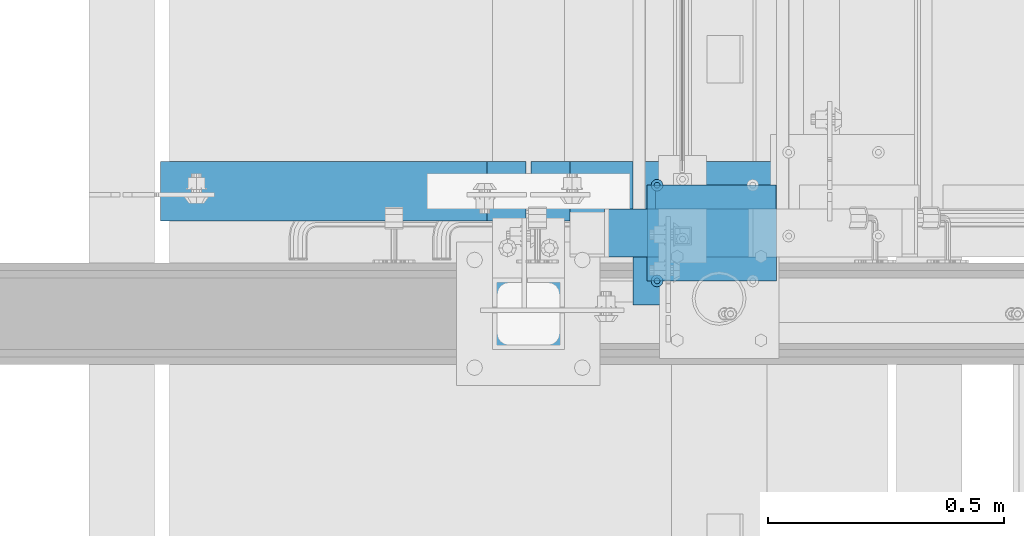
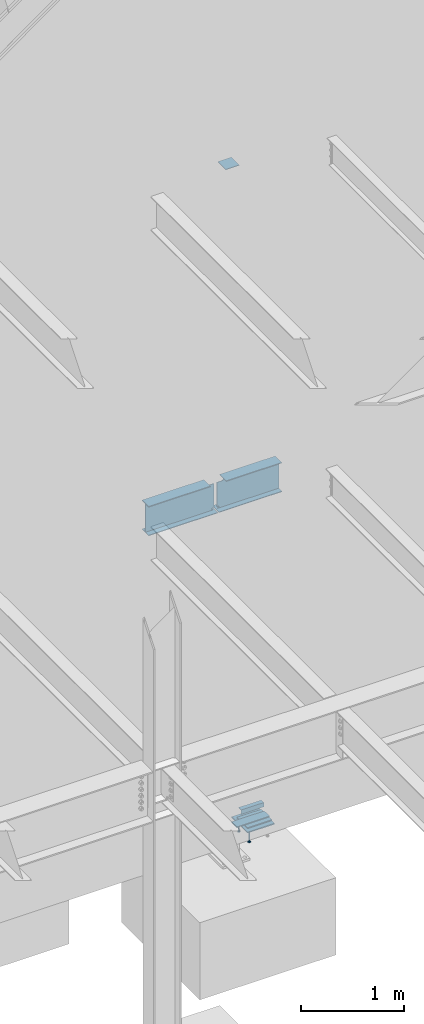
# One storey, part 903 of 1179: 11 beams, 8 elements without a shape of their own.
"""IFC2X3 building model written with IfcOpenShell, lengths in millimetres."""

from ifc_helpers import new_model, si_unit, frame, origin_with_axes, place, context, subcontext, project, spatial, faceted_brep, material, type_object, element, aggregate, save


model = new_model("IFC2X3")

# Units and contexts
model_context = context("Model", 3, precision=1e-05, world=origin_with_axes())
body_context = subcontext(model_context, "Body", "Model", "MODEL_VIEW")
ifc_project = project(units=[si_unit("LENGTHUNIT", "METRE", prefix="MILLI"), si_unit("AREAUNIT", "SQUARE_METRE"), si_unit("VOLUMEUNIT", "CUBIC_METRE"), si_unit("MASSUNIT", "GRAM", prefix="KILO"), si_unit("TIMEUNIT", "SECOND"), si_unit("PLANEANGLEUNIT", "RADIAN"), si_unit("SOLIDANGLEUNIT", "STERADIAN"), si_unit("THERMODYNAMICTEMPERATUREUNIT", "DEGREE_CELSIUS"), si_unit("LUMINOUSINTENSITYUNIT", "LUMEN")], contexts=[model_context])

# Site, building, storey
site_placement = place(None, origin_with_axes())
site = spatial("IfcSite", under=ifc_project, at=site_placement, CompositionType="ELEMENT")
building_placement = place(site_placement, origin_with_axes())
building = spatial("IfcBuilding", under=site, at=building_placement, Name="Undefined", CompositionType="ELEMENT")
storey_placement = place(building_placement, origin_with_axes())
storey = spatial("IfcBuildingStorey", under=building, at=storey_placement, Name="Undefined", CompositionType="ELEMENT", Elevation=0.0)

# Assembly, beam
assembly_1_placement = place(storey_placement, origin_with_axes())
assembly_1 = element("IfcElementAssembly", 1, at=assembly_1_placement, inside=storey, Name="STAIR", AssemblyPlace="NOTDEFINED", PredefinedType="RIGID_FRAME")
ifc_material_1 = material(Name="STEEL/A36")
beam_type_1 = type_object("IfcBeamType", Name="L2X2X3/16", PredefinedType="NOTDEFINED")
beam_1_placement = place(assembly_1_placement, frame((19802.8678269992, 38233.3500000384, 97.6973832800095), z_axis=(0.0, 1.0, 0.0), x_axis=(-1.0, 0.0, 0.0)))
beam_1 = element("IfcBeam", 2, at=beam_1_placement, type_object=beam_type_1, material=ifc_material_1, Name="ANGLE", ObjectType="L2X2X3/16", context=body_context, shape_type="Brep", body=[
    faceted_brep([(0.0, 25.3999999999996, -25.4000000000015), (0.0, 25.3999999999996, 25.4000000000015), (254.0, 25.3999999999996, 25.4000000000001), (254.0, 25.3999999999996, -25.4000000000001), (0.0, 20.6374999999998, 25.4000000000015), (254.0, 20.6374999999998, 25.4000000000001), (0.0, 20.6374999999998, -20.6374999999971), (254.0, 20.6374999999998, -20.6374999999998), (0.0, -25.3999999999996, -20.6374999999971), (254.0, -25.3999999999996, -20.6374999999998), (0.0, -25.3999999999996, -25.4000000000015), (254.0, -25.3999999999996, -25.4000000000001)], [[[0, 1, 2, 3]], [[1, 4, 5, 2]], [[4, 6, 7, 5]], [[6, 8, 9, 7]], [[8, 10, 11, 9]], [[10, 0, 3, 11]], [[5, 7, 9, 11, 3, 2]], [[10, 8, 6, 4, 1, 0]]]),
])

# Assembly, beams
assembly_2_placement = place(storey_placement, origin_with_axes())
assembly_2 = element("IfcElementAssembly", 3, at=assembly_2_placement, inside=storey, Name="EMBED", AssemblyPlace="NOTDEFINED", PredefinedType="RIGID_FRAME")
ifc_material_2 = material(Name="STEEL/A108")
beam_type_2 = type_object("IfcBeamType", Name="STUD_1/2-DIA", PredefinedType="NOTDEFINED")
beam_2_placement = place(assembly_2_placement, frame((19551.6500003795, 38055.5499999969, -12.6999999999994), z_axis=(0.0, -1.0, 0.0), x_axis=(0.0, 0.0, -1.0)))
beam_2 = element("IfcBeam", 4, at=beam_2_placement, type_object=beam_type_2, material=ifc_material_2, Name="SHEAR STUD", ObjectType="STUD_1/2-DIA", context=body_context, shape_type="Brep", body=[
    faceted_brep([(0.0, -3.1800000667572, 5.5), (0.0, -5.5, 3.1800000667572), (141.732, -5.5, 3.1800000667572), (141.732, -3.1800000667572, 5.5), (0.0, -6.34999999999854, 0.0), (141.732, -6.34999990463257, 0.0), (0.0, -5.5, -3.1800000667572), (141.732, -5.5, -3.1800000667572), (0.0, -3.1800000667572, -5.5), (141.732, -3.1800000667572, -5.5), (0.0, 0.0, -6.34999999999991), (141.732, 0.0, -6.34999990463257), (0.0, 3.1800000667572, -5.5), (141.732, 3.1800000667572, -5.5), (0.0, 5.5, -3.1800000667572), (141.732, 5.5, -3.1800000667572), (0.0, 6.34999999999854, 0.0), (141.732, 6.34999990463257, 0.0), (0.0, 5.5, 3.1800000667572), (141.732, 5.5, 3.1800000667572), (0.0, 3.1800000667572, 5.5), (141.732, 3.1800000667572, 5.5), (0.0, 0.0, 6.34999999999991), (141.732, 0.0, 6.34999990463257), (144.78, -10.9899997711182, 6.34999990463257), (144.78, -6.34000015258789, 10.9899997711182), (144.78, -12.6999998092651, 0.0), (144.78, -10.9899997711182, -6.34999990463257), (144.78, -6.34000015258789, -10.9899997711182), (144.78, 0.0, -12.6899995803833), (144.78, 6.34000015258789, -10.9899997711182), (144.78, 10.9899997711182, -6.34999990463257), (144.78, 12.6999998092651, 0.0), (144.78, 10.9899997711182, 6.34999990463257), (144.78, 6.34000015258789, 10.9899997711182), (144.78, 0.0, 12.6899995803833), (152.4, -10.9899997711182, 6.34999990463257), (152.4, -6.34000015258789, 10.9899997711182), (152.4, -12.6999998092651, 0.0), (152.4, -10.9899997711182, -6.34999990463257), (152.4, -6.34000015258789, -10.9899997711182), (152.4, 0.0, -12.6899995803833), (152.4, 6.34000015258789, -10.9899997711182), (152.4, 10.9899997711182, -6.34999990463257), (152.4, 12.6999998092651, 0.0), (152.4, 10.9899997711182, 6.34999990463257), (152.4, 6.34000015258789, 10.9899997711182), (152.4, 0.0, 12.6899995803833)], [[[0, 1, 2, 3]], [[1, 4, 5, 2]], [[4, 6, 7, 5]], [[6, 8, 9, 7]], [[8, 10, 11, 9]], [[10, 12, 13, 11]], [[12, 14, 15, 13]], [[14, 16, 17, 15]], [[16, 18, 19, 17]], [[18, 20, 21, 19]], [[20, 22, 23, 21]], [[22, 0, 3, 23]], [[22, 20, 18, 16, 14, 12, 10, 8, 6, 4, 1, 0]], [[3, 2, 24, 25]], [[2, 5, 26, 24]], [[5, 7, 27, 26]], [[7, 9, 28, 27]], [[9, 11, 29, 28]], [[11, 13, 30, 29]], [[13, 15, 31, 30]], [[15, 17, 32, 31]], [[17, 19, 33, 32]], [[19, 21, 34, 33]], [[21, 23, 35, 34]], [[23, 3, 25, 35]], [[25, 24, 36, 37]], [[24, 26, 38, 36]], [[26, 27, 39, 38]], [[27, 28, 40, 39]], [[28, 29, 41, 40]], [[29, 30, 42, 41]], [[30, 31, 43, 42]], [[31, 32, 44, 43]], [[32, 33, 45, 44]], [[33, 34, 46, 45]], [[34, 35, 47, 46]], [[35, 25, 37, 47]], [[38, 39, 40, 41, 42, 43, 44, 45, 46, 47, 37, 36]]]),
])
beam_3_placement = place(assembly_2_placement, frame((19551.6500003795, 38258.7499999968, -12.6999999999994), z_axis=(0.0, -1.0, 0.0), x_axis=(0.0, 0.0, -1.0)))
beam_3 = element("IfcBeam", 5, at=beam_3_placement, type_object=beam_type_2, material=ifc_material_2, Name="SHEAR STUD", ObjectType="STUD_1/2-DIA", context=body_context, shape_type="Brep", body=[
    faceted_brep([(0.0, -3.1800000667572, 5.5), (0.0, -5.5, 3.1800000667572), (141.732, -5.5, 3.1800000667572), (141.732, -3.1800000667572, 5.5), (0.0, -6.34999999999854, 0.0), (141.732, -6.34999990463257, 0.0), (0.0, -5.5, -3.1800000667572), (141.732, -5.5, -3.1800000667572), (0.0, -3.1800000667572, -5.5), (141.732, -3.1800000667572, -5.5), (0.0, 0.0, -6.34999999999991), (141.732, 0.0, -6.34999990463257), (0.0, 3.1800000667572, -5.5), (141.732, 3.1800000667572, -5.5), (0.0, 5.5, -3.1800000667572), (141.732, 5.5, -3.1800000667572), (0.0, 6.34999999999854, 0.0), (141.732, 6.34999990463257, 0.0), (0.0, 5.5, 3.1800000667572), (141.732, 5.5, 3.1800000667572), (0.0, 3.1800000667572, 5.5), (141.732, 3.1800000667572, 5.5), (0.0, 0.0, 6.34999999999991), (141.732, 0.0, 6.34999990463257), (144.78, -10.9899997711182, 6.34999990463257), (144.78, -6.34000015258789, 10.9899997711182), (144.78, -12.6999998092651, 0.0), (144.78, -10.9899997711182, -6.34999990463257), (144.78, -6.34000015258789, -10.9899997711182), (144.78, 0.0, -12.6899995803833), (144.78, 6.34000015258789, -10.9899997711182), (144.78, 10.9899997711182, -6.34999990463257), (144.78, 12.6999998092651, 0.0), (144.78, 10.9899997711182, 6.34999990463257), (144.78, 6.34000015258789, 10.9899997711182), (144.78, 0.0, 12.6899995803833), (152.4, -10.9899997711182, 6.34999990463257), (152.4, -6.34000015258789, 10.9899997711182), (152.4, -12.6999998092651, 0.0), (152.4, -10.9899997711182, -6.34999990463257), (152.4, -6.34000015258789, -10.9899997711182), (152.4, 0.0, -12.6899995803833), (152.4, 6.34000015258789, -10.9899997711182), (152.4, 10.9899997711182, -6.34999990463257), (152.4, 12.6999998092651, 0.0), (152.4, 10.9899997711182, 6.34999990463257), (152.4, 6.34000015258789, 10.9899997711182), (152.4, 0.0, 12.6899995803833)], [[[0, 1, 2, 3]], [[1, 4, 5, 2]], [[4, 6, 7, 5]], [[6, 8, 9, 7]], [[8, 10, 11, 9]], [[10, 12, 13, 11]], [[12, 14, 15, 13]], [[14, 16, 17, 15]], [[16, 18, 19, 17]], [[18, 20, 21, 19]], [[20, 22, 23, 21]], [[22, 0, 3, 23]], [[22, 20, 18, 16, 14, 12, 10, 8, 6, 4, 1, 0]], [[3, 2, 24, 25]], [[2, 5, 26, 24]], [[5, 7, 27, 26]], [[7, 9, 28, 27]], [[9, 11, 29, 28]], [[11, 13, 30, 29]], [[13, 15, 31, 30]], [[15, 17, 32, 31]], [[17, 19, 33, 32]], [[19, 21, 34, 33]], [[21, 23, 35, 34]], [[23, 3, 25, 35]], [[25, 24, 36, 37]], [[24, 26, 38, 36]], [[26, 27, 39, 38]], [[27, 28, 40, 39]], [[28, 29, 41, 40]], [[29, 30, 42, 41]], [[30, 31, 43, 42]], [[31, 32, 44, 43]], [[32, 33, 45, 44]], [[33, 34, 46, 45]], [[34, 35, 47, 46]], [[35, 25, 37, 47]], [[38, 39, 40, 41, 42, 43, 44, 45, 46, 47, 37, 36]]]),
])

# Beam
beam_type_3 = type_object("IfcBeamType", PredefinedType="NOTDEFINED")
beam_4_placement = place(assembly_1_placement, frame((19808.6125266123, 38157.1500000141, 17.5288666593273), z_axis=(0.0, -1.0, 0.0), x_axis=(-1.0, 0.0, 0.0)))
beam_4 = element("IfcBeam", 6, at=beam_4_placement, type_object=beam_type_3, material=ifc_material_1, Name="PLATE", context=body_context, shape_type="Brep", body=[
    faceted_brep([(0.0, 4.76249999999982, -50.7999999999993), (0.0, 4.76249999999982, 50.7999999999993), (368.087195261149, 4.76249999999948, 50.8000000000029), (368.087195261149, 4.76249999999948, -50.8000000000029), (0.0, -4.76249999999982, 50.7999999999993), (368.087195261145, -4.76250000000052, 50.8000000000029), (0.0, -4.76249999999982, -50.7999999999993), (368.087195261145, -4.76250000000052, -50.8000000000029)], [[[0, 1, 2, 3]], [[1, 4, 5, 2]], [[4, 6, 7, 5]], [[6, 0, 3, 7]], [[5, 7, 3, 2]], [[6, 4, 1, 0]]]),
])

aggregate(assembly_1, [beam_4, beam_1])

# Assembly, beam
assembly_3_placement = place(storey_placement, origin_with_axes())
assembly_3 = element("IfcElementAssembly", 7, at=assembly_3_placement, inside=storey, Name="LAYER", AssemblyPlace="NOTDEFINED", PredefinedType="RIGID_FRAME")
beam_type_4 = type_object("IfcBeamType", PredefinedType="NOTDEFINED")
beam_5_placement = place(assembly_3_placement, frame((19805.6497468088, 38157.1499999975, 6.34981667033696), z_axis=(0.0, -1.0, 0.0), x_axis=(-1.0, 0.0, 0.0)))
beam_5 = element("IfcBeam", 8, at=beam_5_placement, type_object=beam_type_4, material=ifc_material_1, Name="LAYER", context=body_context, shape_type="Brep", body=[
    faceted_brep([(1.77351466845721e-11, 3.17500000001064, -101.600000000029), (0.0, 3.17500000000018, 101.599999999999), (275.436220746942, 3.17500000000001, 101.599999999999), (275.436220746942, 3.17500000000001, -101.599999999999), (0.0, -3.17500000000018, 101.599999999999), (275.436220746949, -3.17499999999999, 101.599999999999), (1.8644641386345e-11, -3.17499999998927, -101.600000000031), (275.436220746949, -3.17499999999999, -101.599999999999)], [[[0, 1, 2, 3]], [[1, 4, 5, 2]], [[4, 6, 7, 5]], [[6, 0, 3, 7]], [[5, 7, 3, 2]], [[6, 4, 1, 0]]]),
])
aggregate(assembly_3, [beam_5])

assembly_4_placement = place(storey_placement, origin_with_axes())
assembly_4 = element("IfcElementAssembly", 9, at=assembly_4_placement, inside=storey, Name="BEAM", AssemblyPlace="NOTDEFINED", PredefinedType="RIGID_FRAME")
ifc_material_3 = material(Name="STEEL/A992")
beam_type_5 = type_object("IfcBeamType", Name="W14X22", PredefinedType="NOTDEFINED")
beam_6_placement = place(assembly_4_placement, frame((18415.0, 38246.0500000005, 3927.475), z_axis=(0.0, 0.0, 1.0), x_axis=(1.0, 0.0, 0.0)))
beam_6 = element("IfcBeam", 10, at=beam_6_placement, type_object=beam_type_5, material=ifc_material_3, Name="BEAM", ObjectType="W14X22", context=body_context, shape_type="Brep", body=[
    faceted_brep([(846.931249999998, -3.17500000000291, -166.3875), (846.931249999998, 3.17500000000291, -166.3875), (838.993749999998, 3.17500000000291, -166.3875), (838.993749999998, -3.17500000000291, -166.3875), (825.823690306723, 3.17500000000291, -160.932282657781), (825.823690306723, -3.17500000000291, -160.932282657781), (821.549002259999, 3.17500000000291, -157.42413636819), (821.549002259999, -3.17500000000291, -157.42413636819), (819.94375038147, 3.17500000000291, -152.132330110611), (819.94375038147, -3.17500000000291, -152.132330110611), (821.549002259999, 3.17500000000291, -146.840523853033), (821.549002259999, -3.17500000000291, -146.840523853033), (825.823690452704, 3.17500000000291, -143.332377915873), (825.823690452704, -3.17500000000291, -143.332377915873), (846.931249999998, -3.17500000000291, -142.907330326454), (846.931249999998, 3.17500000000291, -142.907330326454), (82.5499999999993, 3.17500000000291, 166.6875), (82.5499999999993, 63.5, 166.6875), (775.493749999998, 63.5, 166.6875), (775.493749999998, 3.17500000000291, 166.6875), (82.5499999999993, -63.5, -174.625), (82.5499999999993, 63.5, -174.625), (858.043749999997, 63.5, -174.625), (858.043749999997, -63.5, -174.625), (846.931249999998, -63.5, -166.6875), (82.5499999999993, -63.5, -166.6875), (858.043749999997, -63.5, -166.6875), (846.931249999998, -3.17500000000291, -166.6875), (82.5499999999993, -3.17500000000291, -166.6875), (858.043749999997, -3.17500000000291, -166.6875), (846.931249999998, 63.5, -166.6875), (82.5499999999993, 63.5, -166.6875), (82.5499999999993, 3.17500000000291, -166.6875), (846.931249999998, 3.17500000000291, -166.6875), (858.043749999997, 3.17500000000291, -166.6875), (858.043749999997, 63.5, -166.6875), (82.5499999999993, -3.17500000000291, 166.6875), (82.5499999999993, -63.5, 166.6875), (82.5499999999993, -63.5, 174.625), (82.5499999999993, 63.5, 174.625), (775.493749999998, -3.17500000000291, 166.6875), (775.493749999998, -63.5, 166.6875), (775.493749999998, -63.5, 174.625), (775.493749999998, 63.5, 174.625), (775.493749999998, -3.17500000000291, 155.574999809468), (775.493749999998, 3.17500000000291, 155.574999809468), (776.460479922585, -3.17500000000291, 150.714920291423), (776.460479922585, 3.17500000000291, 150.714920291423), (779.213493823063, -3.17500000000291, 146.594743823269), (779.213493823063, 3.17500000000291, 146.594743823269), (783.333670291217, -3.17500000000291, 143.841729922791), (783.333670291217, 3.17500000000291, 143.841729922791), (788.193749809263, -3.17500000000291, 142.875000000203), (788.193749809263, 3.17500000000291, 142.875000000203), (846.931249999998, -3.17500000000291, 142.875000000203), (846.931249999998, 3.17500000000291, 142.875000000203)], [[[0, 1, 2, 3]], [[3, 2, 4, 5]], [[5, 4, 6, 7]], [[7, 6, 8, 9]], [[9, 8, 10, 11]], [[11, 10, 12, 13]], [[14, 13, 12, 15]], [[16, 17, 18, 19]], [[20, 21, 22, 23]], [[24, 25, 20, 23, 26]], [[27, 28, 25, 24, 26, 29]], [[30, 31, 32, 33, 34, 35]], [[29, 34, 33, 27]], [[26, 23, 22, 35, 34, 29]], [[21, 31, 30, 35, 22]], [[20, 25, 28, 36, 37, 38, 39, 17, 16, 32, 31, 21]], [[37, 36, 40, 41]], [[38, 37, 41, 42]], [[39, 38, 42, 43]], [[17, 39, 43, 18]], [[42, 41, 40, 44, 45, 19, 18, 43]], [[46, 47, 45, 44]], [[48, 49, 47, 46]], [[50, 51, 49, 48]], [[52, 53, 51, 50]], [[53, 52, 54, 55]], [[55, 54, 14, 15]], [[10, 8, 6, 4, 2, 1, 33, 32, 16, 19, 45, 47, 49, 51, 53, 55, 15, 12]], [[27, 33, 1, 0]], [[54, 52, 50, 48, 46, 44, 40, 36, 28, 27, 0, 3, 5, 7, 9, 11, 13, 14]]]),
])
aggregate(assembly_4, [beam_6])

assembly_5_placement = place(storey_placement, origin_with_axes())
assembly_5 = element("IfcElementAssembly", 11, at=assembly_5_placement, inside=storey, Name="BEAM", AssemblyPlace="NOTDEFINED", PredefinedType="RIGID_FRAME")
beam_7_placement = place(assembly_5_placement, frame((19278.6, 38246.0500000005, 3927.475), z_axis=(0.0, 0.0, 1.0), x_axis=(1.0, 0.0, 0.0)))
beam_7 = element("IfcBeam", 12, at=beam_7_placement, type_object=beam_type_5, material=ifc_material_3, Name="BEAM", ObjectType="W14X22", context=body_context, shape_type="Brep", body=[
    faceted_brep([(16.6687500000044, -3.17500000000291, -142.907330326454), (16.6687500000044, 3.17500000000291, -142.907330326454), (37.7763095472983, 3.17500000000291, -143.332377915873), (37.7763095472983, -3.17500000000291, -143.332377915873), (42.0509977400034, 3.17500000000291, -146.840523853033), (42.0509977400034, -3.17500000000291, -146.840523853033), (24.6062500000044, -3.17500000000291, -166.3875), (24.6062500000044, 3.17500000000291, -166.3875), (16.6687500000044, 3.17500000000291, -166.3875), (16.6687500000044, -3.17500000000291, -166.3875), (37.7763096932795, -3.17500000000291, -160.932282657781), (37.7763096932795, 3.17500000000291, -160.932282657781), (42.0509977400034, -3.17500000000291, -157.42413636819), (42.0509977400034, 3.17500000000291, -157.42413636819), (43.6562496185325, -3.17500000000291, -152.132330110611), (43.6562496185325, 3.17500000000291, -152.132330110611), (711.199999999997, -63.5, 166.6875), (711.199999999997, -63.5, 174.625), (88.1062500000044, -63.5, 174.625), (88.1062500000044, -63.5, 166.6875), (711.199999999997, 63.5, 174.625), (88.1062500000044, 63.5, 174.625), (711.199999999997, 63.5, 166.6875), (88.1062500000044, 63.5, 166.6875), (711.199999999997, 3.17500000000291, 166.6875), (88.1062500000044, 3.17500000000291, 166.6875), (75.4062501907392, -3.17500000000291, 142.875000000076), (75.4062501907392, 3.17500000000291, 142.875000000076), (16.6687500000007, 3.17500000000291, 142.875), (16.6687500000007, -3.17500000000291, 142.875), (80.2663297087856, -3.17500000000291, 143.841729922664), (80.2663297087856, 3.17500000000291, 143.841729922664), (84.3865061769393, -3.17500000000291, 146.594743823142), (84.3865061769393, 3.17500000000291, 146.594743823142), (87.1395200774168, -3.17500000000291, 150.714920291296), (87.1395200774168, 3.17500000000291, 150.714920291296), (88.1062500000044, -3.17500000000291, 155.574999809341), (88.1062500000044, 3.17500000000291, 155.574999809341), (88.1062500000044, -3.17500000000291, 166.6875), (711.199999999997, -3.17500000000291, 166.6875), (16.6687500000044, 3.17500000000291, -166.6875), (711.199999999997, 3.17500000000291, -166.6875), (711.199999999997, 63.5, -166.6875), (16.6687500000044, 63.5, -166.6875), (5.55625000000509, 63.5, -166.6875), (5.55625000000509, 3.17500000000291, -166.6875), (711.199999999997, -63.5, -174.625), (711.199999999997, -63.5, -166.6875), (16.6687500000044, -63.5, -166.6875), (5.55625000000509, -63.5, -166.6875), (5.55625000000509, -63.5, -174.625), (711.199999999997, 63.5, -174.625), (5.55625000000509, 63.5, -174.625), (711.199999999997, -3.17500000000291, -166.6875), (16.6687500000044, -3.17500000000291, -166.6875), (5.55625000000509, -3.17500000000291, -166.6875)], [[[0, 1, 2, 3]], [[3, 2, 4, 5]], [[6, 7, 8, 9]], [[10, 11, 7, 6]], [[12, 13, 11, 10]], [[14, 15, 13, 12]], [[5, 4, 15, 14]], [[16, 17, 18, 19]], [[17, 20, 21, 18]], [[20, 22, 23, 21]], [[22, 24, 25, 23]], [[26, 27, 28, 29]], [[30, 31, 27, 26]], [[32, 33, 31, 30]], [[34, 35, 33, 32]], [[36, 37, 35, 34]], [[18, 21, 23, 25, 37, 36, 38, 19]], [[39, 16, 19, 38]], [[40, 41, 42, 43, 44, 45]], [[46, 47, 48, 49, 50]], [[51, 46, 50, 52]], [[43, 42, 51, 52, 44]], [[41, 24, 22, 20, 17, 16, 39, 53, 47, 46, 51, 42]], [[48, 47, 53, 54, 55, 49]], [[44, 52, 50, 49, 55, 45]], [[54, 40, 45, 55]], [[40, 54, 9, 8]], [[2, 1, 28, 27, 31, 33, 35, 37, 25, 24, 41, 40, 8, 7, 11, 13, 15, 4]], [[29, 28, 1, 0]], [[10, 6, 9, 54, 53, 39, 38, 36, 34, 32, 30, 26, 29, 0, 3, 5, 14, 12]]]),
])
aggregate(assembly_5, [beam_7])

assembly_6_placement = place(storey_placement, origin_with_axes())
assembly_6 = element("IfcElementAssembly", 13, at=assembly_6_placement, inside=storey, Name="LAYER", AssemblyPlace="NOTDEFINED", PredefinedType="RIGID_FRAME")
beam_type_6 = type_object("IfcBeamType", PredefinedType="NOTDEFINED")
beam_8_placement = place(assembly_6_placement, frame((19805.6499997814, 38157.1499999975, 11.1786833296632), z_axis=(0.0, -1.0, 0.0), x_axis=(-1.0, 0.0, 0.0)))
beam_8 = element("IfcBeam", 14, at=beam_8_placement, type_object=beam_type_6, material=ifc_material_1, Name="LAYER", context=body_context, shape_type="Brep", body=[
    faceted_brep([(0.0, 1.5875, -101.6), (0.0, 1.5875, 101.6), (275.436220746942, 1.58750000000001, 101.599999999999), (275.436220746942, 1.58750000000001, -101.599999999999), (0.0, -1.5875, 101.6), (275.436220746946, -1.58749999999999, 101.599999999999), (0.0, -1.5875, -101.6), (275.436220746946, -1.58749999999999, -101.599999999999)], [[[0, 1, 2, 3]], [[1, 4, 5, 2]], [[4, 6, 7, 5]], [[6, 0, 3, 7]], [[5, 7, 3, 2]], [[6, 4, 1, 0]]]),
])
aggregate(assembly_6, [beam_8])

assembly_7_placement = place(storey_placement, origin_with_axes())
assembly_7 = element("IfcElementAssembly", 15, at=assembly_7_placement, inside=storey, Name="LAYER", AssemblyPlace="NOTDEFINED", PredefinedType="RIGID_FRAME")
beam_9_placement = place(assembly_7_placement, frame((19805.6499997814, 38157.1499999975, 1.58749999999999), z_axis=(0.0, -1.0, 0.0), x_axis=(-1.0, 0.0, 0.0)))
beam_9 = element("IfcBeam", 16, at=beam_9_placement, type_object=beam_type_6, material=ifc_material_1, Name="LAYER", context=body_context, shape_type="Brep", body=[
    faceted_brep([(0.0, 1.5875, -101.6), (0.0, 1.5875, 101.6), (275.436220746942, 1.58750000000001, 101.599999999999), (275.436220746942, 1.58750000000001, -101.599999999999), (0.0, -1.5875, 101.6), (275.436220746946, -1.58749999999999, 101.599999999999), (0.0, -1.5875, -101.6), (275.436220746946, -1.58749999999999, -101.599999999999)], [[[0, 1, 2, 3]], [[1, 4, 5, 2]], [[4, 6, 7, 5]], [[6, 0, 3, 7]], [[5, 7, 3, 2]], [[6, 4, 1, 0]]]),
])
aggregate(assembly_7, [beam_9])

assembly_8_placement = place(storey_placement, origin_with_axes())
assembly_8 = element("IfcElementAssembly", 17, at=assembly_8_placement, inside=storey, Name="COLUMN", AssemblyPlace="NOTDEFINED", PredefinedType="RIGID_FRAME")
beam_type_7 = type_object("IfcBeamType", PredefinedType="NOTDEFINED")
beam_10_placement = place(assembly_8_placement, frame((19278.6, 37909.5, 8010.525), z_axis=(1.0, 0.0, 0.0), x_axis=(0.0, 1.0, 0.0)))
beam_10 = element("IfcBeam", 18, at=beam_10_placement, type_object=beam_type_7, material=ifc_material_1, Name="PLATE", context=body_context, shape_type="Brep", body=[
    faceted_brep([(-1.47792889038101e-12, 3.17500000000018, -76.1999999999953), (1.36424205265939e-12, 3.17500000000018, 76.1999999999953), (152.399999999989, 3.17500000000018, 76.200000000028), (152.399999999986, 3.17500000000018, -76.1999999999625), (1.36424205265939e-12, -3.17500000000018, 76.1999999999953), (152.399999999989, -3.17500000000018, 76.200000000028), (-1.47792889038101e-12, -3.17500000000018, -76.1999999999953), (152.399999999986, -3.17500000000018, -76.1999999999625)], [[[0, 1, 2, 3]], [[1, 4, 5, 2]], [[4, 6, 7, 5]], [[6, 0, 3, 7]], [[5, 7, 3, 2]], [[6, 4, 1, 0]]]),
])
aggregate(assembly_8, [beam_10])

# Beam
beam_type_8 = type_object("IfcBeamType", PredefinedType="NOTDEFINED")
beam_11_placement = place(assembly_2_placement, frame((19805.6500003795, 38157.1499999969, -6.34999999999954), z_axis=(0.0, 1.0, 0.0), x_axis=(-1.0, 0.0, 0.0)))
beam_11 = element("IfcBeam", 19, at=beam_11_placement, type_object=beam_type_8, material=ifc_material_1, Name="EMBED", context=body_context, shape_type="Brep", body=[
    faceted_brep([(0.0, 6.35, -152.400000000001), (0.0, 6.34999999999854, 152.400000000001), (304.799999999999, 6.35, 152.400000000001), (304.799999999999, 6.35, -152.400000000001), (0.0, -6.34999999999854, 152.400000000001), (304.799999999999, -6.35, 152.400000000001), (0.0, -6.35, -152.400000000001), (304.799999999999, -6.35, -152.400000000001)], [[[0, 1, 2, 3]], [[1, 4, 5, 2]], [[4, 6, 7, 5]], [[6, 0, 3, 7]], [[5, 7, 3, 2]], [[6, 4, 1, 0]]]),
])

aggregate(assembly_2, [beam_2, beam_3, beam_11])

save(model, "model.ifc")
